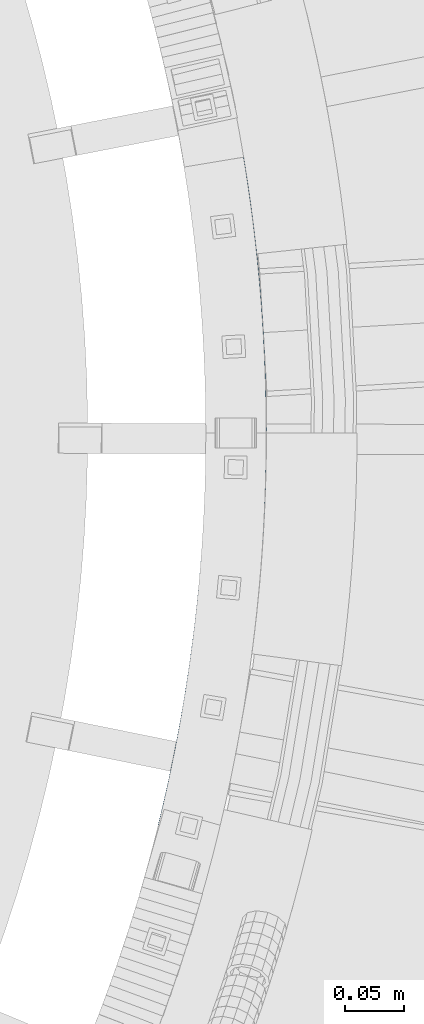
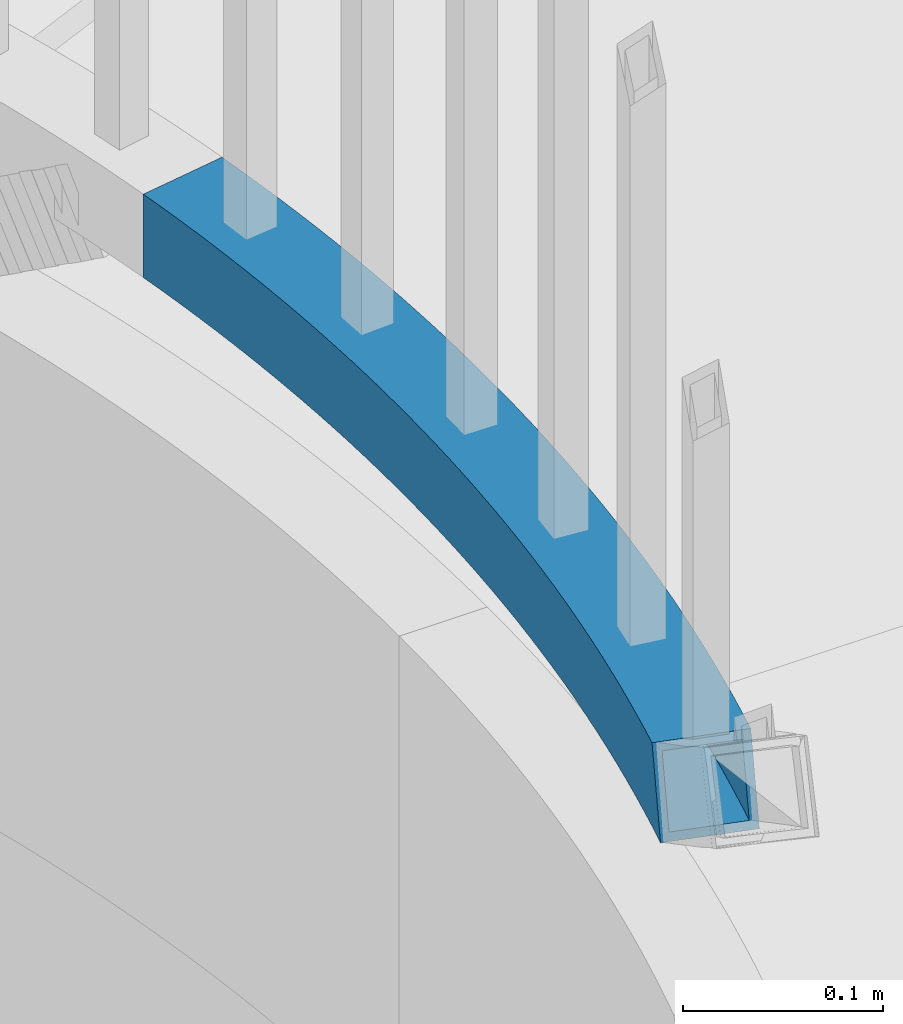
# One storey, part 500 of 975: 1 beam.
"""IFC2X3 building model written with IfcOpenShell, lengths in millimetres."""

from ifc_helpers import new_model, si_unit, frame, origin_with_axes, place, context, subcontext, project, spatial, faceted_brep, material, type_object, element, save


model = new_model("IFC2X3")

# Units and contexts
model_context = context("Model", 3, precision=1e-05, world=origin_with_axes())
body_context = subcontext(model_context, "Body", "Model", "MODEL_VIEW")
ifc_project = project(units=[si_unit("LENGTHUNIT", "METRE", prefix="MILLI"), si_unit("AREAUNIT", "SQUARE_METRE"), si_unit("VOLUMEUNIT", "CUBIC_METRE"), si_unit("MASSUNIT", "GRAM", prefix="KILO"), si_unit("TIMEUNIT", "SECOND"), si_unit("PLANEANGLEUNIT", "RADIAN"), si_unit("SOLIDANGLEUNIT", "STERADIAN"), si_unit("THERMODYNAMICTEMPERATUREUNIT", "DEGREE_CELSIUS"), si_unit("LUMINOUSINTENSITYUNIT", "LUMEN")], contexts=[model_context])

# Site, building, storey
site_placement = place(None, origin_with_axes())
site = spatial("IfcSite", under=ifc_project, at=site_placement, CompositionType="ELEMENT")
building_placement = place(site_placement, origin_with_axes())
building = spatial("IfcBuilding", under=site, at=building_placement, Name="Undefined", CompositionType="ELEMENT")
storey_placement = place(building_placement, origin_with_axes())
storey = spatial("IfcBuildingStorey", under=building, at=storey_placement, Name="Undefined", CompositionType="ELEMENT", Elevation=0.0)

# Beam
ifc_material = material()
beam_type = type_object("IfcBeamType", Name="HSS2X2X.188_TUBES", PredefinedType="NOTDEFINED")
beam_placement = place(storey_placement, frame((36112.7719804333, 3631.78783647588, 2298.70000076294), z_axis=(0.0, 0.0, 1.0), x_axis=(-0.152831050032776, -0.988252331211963, 0.0)))
element("IfcBeam", 1, at=beam_placement, inside=storey, type_object=beam_type, material=ifc_material, Name="HANDRAIL", ObjectType="HSS2X2X.188_TUBES", context=body_context, shape_type="Brep", body=[
    faceted_brep([(535.602146892454, 91.4649751076213, 25.4000000000001), (520.326512477557, 92.4485665877291, 25.4000000000001), (505.04121450457, 93.2683987988567, 25.4000000000001), (489.748008470178, 93.9243775843279, 25.4000000000001), (474.448650779292, 94.4164276058218, 25.4000000000001), (459.144898543333, 94.7444923520379, 25.4000000000001), (443.838509378433, 94.9085341451646, 25.4000000000001), (428.531241203566, 94.9085341452228, 25.4000000000001), (413.224852038664, 94.744492352198, 25.4000000000001), (397.921099802705, 94.4164276060765, 25.4000000000001), (382.621742111818, 93.9243775846844, 25.4000000000001), (367.328536077426, 93.268398799315, 25.4000000000001), (352.043238104439, 92.4485665882894, 25.4000000000001), (336.767603689541, 91.4649751082761, 25.4000000000001), (321.503387219564, 90.3177373234867, 25.4000000000001), (306.252341770007, 89.0069849926876, 25.4000000000001), (291.016218903691, 87.5328686540888, 25.4000000000001), (275.796768469605, 85.895557608048, 25.4000000000001), (260.59573840192, 84.0952398976151, 25.4000000000001), (245.414874519263, 82.1321222869374, 25.4000000000001), (230.255920324194, 80.006430237554, 25.4000000000001), (215.120616802971, 77.7184078824284, 25.4000000000001), (200.010702225611, 75.2683179979649, 25.4000000000001), (184.927911946239, 72.6564419738206, 25.4000000000001), (169.873978203786, 69.8830797805786, 25.4000000000001), (154.850629923059, 66.9485499352886, 25.4000000000001), (139.859592516148, 63.8531894648986, 25.4000000000001), (124.902587684295, 60.5973538675753, 25.4000000000001), (109.981333220136, 57.1814170717917, 25.4000000000001), (95.0975428104266, 53.6057713934788, 25.4000000000001), (80.2529258392278, 49.870827490915, 25.4000000000001), (65.4491871915761, 45.9770143175774, 25.4000000000001), (50.6880270576876, 41.9247790728405, 25.4000000000001), (35.9711407376926, 37.7145871507091, 25.4000000000001), (21.3002184469278, 33.3469220862535, 25.4000000000001), (6.67694512182607, 28.8222855001659, 25.4000000000001), (-7.89699977360578, 24.1411970410845, 25.4000000000001), (7.8969997736076, -24.1411970410918, 25.4000000000001), (21.9526148474361, -19.6265938928409, 25.4000000000001), (36.0558039600437, -15.26287832651, 25.4000000000001), (50.2049473784245, -11.0505515091718, 25.4000000000001), (64.3984200917712, -6.99009722112532, 25.4000000000001), (78.6345919981231, -3.0819818002783, 25.4000000000001), (92.9118280915682, 0.673345911382057, 25.4000000000001), (107.228488650027, 4.27545461931732, 25.4000000000001), (121.582929423572, 7.72393062600895, 25.4000000000001), (135.973501823266, 11.0183778784412, 25.4000000000001), (150.398553110501, 14.1584180136488, 25.4000000000001), (164.856426586812, 17.143690402052, 25.4000000000001), (179.345461784151, 19.9738521889958, 25.4000000000001), (193.863994655585, 22.6485783340613, 25.4000000000001), (208.410357766412, 25.1675616484135, 25.4000000000001), (222.982880485662, 27.5305128300824, 25.4000000000001), (237.579889177972, 29.737160497185, 25.4000000000001), (252.19970739579, 31.7872512190879, 25.4000000000001), (266.840656071921, 33.6805495455337, 25.4000000000001), (281.501053712373, 35.4168380336632, 25.4000000000001), (296.179216589451, 36.9959172729723, 25.4000000000001), (310.873458935159, 38.417605908282, 25.4000000000001), (325.582093134786, 39.6817406604678, 25.4000000000001), (340.303429920741, 40.7881763453115, 25.4000000000001), (355.035778566551, 41.7367858900907, 25.4000000000001), (369.777447081053, 42.5274603482394, 25.4000000000001), (384.526742402701, 43.1601089118121, 25.4000000000001), (399.281970594027, 43.6346589219465, 25.4000000000001), (414.041437036178, 43.9510558771872, 25.4000000000001), (428.803446623542, 44.1092634397428, 25.4000000000001), (443.566303958429, 44.1092634396919, 25.4000000000001), (458.328313545793, 43.9510558770344, 25.4000000000001), (473.087779987942, 43.6346589217064, 25.4000000000001), (487.843008179267, 43.1601089114702, 25.4000000000001), (502.592303500916, 42.5274603477956, 25.4000000000001), (517.333972015418, 41.7367858895523, 25.4000000000001), (532.066320661226, 40.7881763446712, 25.4000000000001), (544.641376281192, 39.8430522380586, 25.4000000000001), (550.866363362431, 90.3177373227227, 25.4000000000001), (546.787657447179, 39.6817406597329, -25.4000000000001), (559.66859210903, 38.5746876915873, -25.4000000000001), (546.787657447179, 39.6817406597329, 18.1526137053297), (532.066320661226, 40.7881763446712, -25.4000000000001), (517.333972015418, 41.7367858895523, -25.4000000000001), (502.592303500916, 42.5274603477956, -25.4000000000001), (487.843008179267, 43.1601089114702, -25.4000000000001), (473.087779987942, 43.6346589217064, -25.4000000000001), (458.328313545793, 43.9510558770344, -25.4000000000001), (443.566303958429, 44.1092634396919, -25.4000000000001), (428.803446623542, 44.1092634397428, -25.4000000000001), (414.041437036178, 43.9510558771872, -25.4000000000001), (399.281970594027, 43.6346589219465, -25.4000000000001), (384.526742402701, 43.1601089118121, -25.4000000000001), (369.777447081053, 42.5274603482394, -25.4000000000001), (355.035778566551, 41.7367858900907, -25.4000000000001), (340.303429920741, 40.7881763453115, -25.4000000000001), (325.582093134786, 39.6817406604678, -25.4000000000001), (310.873458935159, 38.417605908282, -25.4000000000001), (296.179216589451, 36.9959172729723, -25.4000000000001), (281.501053712373, 35.4168380336632, -25.4000000000001), (266.840656071921, 33.6805495455337, -25.4000000000001), (252.19970739579, 31.7872512190879, -25.4000000000001), (237.579889177972, 29.737160497185, -25.4000000000001), (222.982880485662, 27.5305128300824, -25.4000000000001), (208.410357766412, 25.1675616484135, -25.4000000000001), (193.863994655585, 22.6485783340613, -25.4000000000001), (179.345461784151, 19.9738521889958, -25.4000000000001), (164.856426586812, 17.143690402052, -25.4000000000001), (150.398553110501, 14.1584180136488, -25.4000000000001), (135.973501823266, 11.0183778784412, -25.4000000000001), (121.582929423572, 7.72393062600895, -25.4000000000001), (107.228488650027, 4.27545461931732, -25.4000000000001), (92.9118280915682, 0.673345911382057, -25.4000000000001), (78.6345919981231, -3.0819818002783, -25.4000000000001), (64.3984200917712, -6.99009722112532, -25.4000000000001), (50.2049473784245, -11.0505515091718, -25.4000000000001), (36.0558039600437, -15.26287832651, -25.4000000000001), (21.9526148474361, -19.6265938928409, -25.4000000000001), (7.8969997736076, -24.1411970410918, -25.4000000000001), (-7.89699977360578, 24.1411970410845, -25.4000000000001), (6.67694512182607, 28.8222855001659, -25.4000000000001), (21.3002184469278, 33.3469220862535, -25.4000000000001), (35.9711407376926, 37.7145871507091, -25.4000000000001), (50.6880270576876, 41.9247790728405, -25.4000000000001), (65.4491871915761, 45.9770143175774, -25.4000000000001), (80.2529258392278, 49.870827490915, -25.4000000000001), (95.0975428104266, 53.6057713934788, -25.4000000000001), (109.981333220136, 57.1814170717917, -25.4000000000001), (124.902587684295, 60.5973538675753, -25.4000000000001), (139.859592516148, 63.8531894648986, -25.4000000000001), (154.850629923059, 66.9485499352886, -25.4000000000001), (169.873978203786, 69.8830797805786, -25.4000000000001), (184.927911946239, 72.6564419738206, -25.4000000000001), (200.010702225611, 75.2683179979649, -25.4000000000001), (215.120616802971, 77.7184078824284, -25.4000000000001), (230.255920324194, 80.006430237554, -25.4000000000001), (245.414874519263, 82.1321222869374, -25.4000000000001), (260.59573840192, 84.0952398976151, -25.4000000000001), (275.796768469605, 85.895557608048, -25.4000000000001), (291.016218903691, 87.5328686540888, -25.4000000000001), (306.252341770007, 89.0069849926876, -25.4000000000001), (321.503387219564, 90.3177373234867, -25.4000000000001), (336.767603689541, 91.4649751082761, -25.4000000000001), (352.043238104439, 92.4485665882894, -25.4000000000001), (367.328536077426, 93.268398799315, -25.4000000000001), (382.621742111818, 93.9243775846844, -25.4000000000001), (397.921099802705, 94.4164276060765, -25.4000000000001), (413.224852038664, 94.744492352198, -25.4000000000001), (428.531241203566, 94.9085341452228, -25.4000000000001), (443.838509378433, 94.9085341451646, -25.4000000000001), (459.144898543333, 94.7444923520379, -25.4000000000001), (474.448650779292, 94.4164276058218, -25.4000000000001), (489.748008470178, 93.9243775843279, -25.4000000000001), (505.04121450457, 93.2683987988567, -25.4000000000001), (520.326512477557, 92.4485665877291, -25.4000000000001), (535.602146892454, 91.4649751076213, -25.4000000000001), (550.866363362431, 90.3177373227227, -25.4000000000001), (566.11740881199, 89.0069849918145, -25.4000000000001), (517.614522683742, 46.4910153300079, -20.6374999999998), (517.614522683742, 46.4910153300079, 20.6374999999998), (532.397804370406, 45.5391262286939, 20.6374999999998), (532.397804370406, 45.5391262286939, -20.6374999999998), (502.821888907509, 47.2844233275828, -20.6374999999998), (502.821888907509, 47.2844233275828, 20.6374999999998), (488.021601956541, 47.9192590995517, -20.6374999999998), (488.021601956541, 47.9192590995517, 20.6374999999998), (473.215361624631, 48.3954497358427, -20.6374999999998), (473.215361624631, 48.3954497358427, 20.6374999999998), (458.404868389312, 48.7129405465676, -20.6374999999998), (458.404868389312, 48.7129405465676, 20.6374999999998), (443.591823216555, 48.8716950683302, -20.6374999999998), (443.591823216555, 48.8716950683302, 20.6374999999998), (428.777927365418, 48.8716950683811, -20.6374999999998), (428.777927365418, 48.8716950683811, 20.6374999999998), (413.964882192662, 48.7129405467131, -20.6374999999998), (413.964882192662, 48.7129405467131, 20.6374999999998), (399.15438895734, 48.3954497360901, -20.6374999999998), (399.15438895734, 48.3954497360901, 20.6374999999998), (384.348148625431, 47.9192590998937, -20.6374999999998), (384.348148625431, 47.9192590998937, 20.6374999999998), (369.547861674464, 47.2844233280266, -20.6374999999998), (369.547861674464, 47.2844233280266, 20.6374999999998), (354.755227898229, 46.4910153305464, -20.6374999999998), (354.755227898229, 46.4910153305464, 20.6374999999998), (339.971946211566, 45.5391262293342, -20.6374999999998), (339.971946211566, 45.5391262293342, 20.6374999999998), (325.199714455235, 44.4288653476251, -20.6374999999998), (325.199714455235, 44.4288653476251, 20.6374999999998), (310.440229200925, 43.1603601974421, -20.6374999999998), (310.440229200925, 43.1603601974421, 20.6374999999998), (295.695185556411, 41.733756464957, -20.6374999999998), (295.695185556411, 41.733756464957, 20.6374999999998), (280.966276970861, 40.1492179937632, -20.6374999999998), (280.966276970861, 40.1492179937632, 20.6374999999998), (266.255195040359, 38.4069267660379, -20.6374999999998), (266.255195040359, 38.4069267660379, 20.6374999999998), (251.563629313614, 36.5070828817043, -20.6374999999998), (251.563629313614, 36.5070828817043, 20.6374999999998), (236.89326709793, 34.4499045353441, -20.6374999999998), (236.89326709793, 34.4499045353441, 20.6374999999998), (222.245793265411, 32.2356279912419, -20.6374999999998), (222.245793265411, 32.2356279912419, 20.6374999999998), (207.622890059461, 29.8645075561872, -20.6374999999998), (207.622890059461, 29.8645075561872, 20.6374999999998), (193.026236901582, 27.3368155502903, -20.6374999999998), (193.026236901582, 27.3368155502903, 20.6374999999998), (178.457510198492, 24.6528422757037, -20.6374999999998), (178.457510198492, 24.6528422757037, 20.6374999999998), (163.918383149585, 21.8128959832902, -20.6374999999998), (163.918383149585, 21.8128959832902, 20.6374999999998), (149.41052555478, 18.8173028371966, -20.6374999999998), (149.41052555478, 18.8173028371966, 20.6374999999998), (134.935603622738, 15.6664068774335, -20.6374999999998), (134.935603622738, 15.6664068774335, 20.6374999999998), (120.495279779501, 12.3605699803011, -20.6374999999998), (120.495279779501, 12.3605699803011, 20.6374999999998), (106.091212477566, 8.90017181688745, -20.6374999999998), (106.091212477566, 8.90017181688745, 20.6374999999998), (91.7250560054108, 5.28560980946349, -20.6374999999998), (91.7250560054108, 5.28560980946349, 20.6374999999998), (77.3984602975088, 1.51729908577545, -20.6374999999998), (77.3984602975088, 1.51729908577545, 20.6374999999998), (63.1130707448265, -2.40432756856899, -20.6374999999998), (63.1130707448265, -2.40432756856899, 20.6374999999998), (48.8705280058548, -6.47881975980999, -20.6374999999998), (48.8705280058548, -6.47881975980999, 20.6374999999998), (34.6724678181909, -10.7057095378113, -20.6374999999998), (34.6724678181909, -10.7057095378113, 20.6374999999998), (20.5205208106599, -15.0845114497424, -20.6374999999998), (20.5205208106599, -15.0845114497424, 20.6374999999998), (6.41631231605606, -19.6147225958921, -20.6374999999998), (6.41631231605606, -19.6147225958921, 20.6374999999998), (-6.41631231605606, 19.6147225958848, 20.6374999999998), (-6.41631231605606, 19.6147225958848, -20.6374999999998), (8.10903915860217, 24.2802030570747, -20.6374999999998), (8.10903915860217, 24.2802030570747, 20.6374999999998), (22.6835545887825, 28.7897532975621, -20.6374999999998), (22.6835545887825, 28.7897532975621, 20.6374999999998), (37.3055601102606, 33.1428554013401, -20.6374999999998), (37.3055601102606, 33.1428554013401, 20.6374999999998), (51.9733764046323, 37.3390094202841, -20.6374999999998), (51.9733764046323, 37.3390094202841, 20.6374999999998), (66.6853188921905, 41.3777334315164, -20.6374999999998), (66.6853188921905, 41.3777334315164, 20.6374999999998), (81.4396979253852, 45.2585635928335, -20.6374999999998), (81.4396979253852, 45.2585635928335, 20.6374999999998), (96.2348189828899, 48.9810541959014, -20.6374999999998), (96.2348189828899, 48.9810541959014, 20.6374999999998), (111.068982864208, 52.5447777174923, -20.6374999999998), (111.068982864208, 52.5447777174923, 20.6374999999998), (125.940485884823, 55.9493248685831, -20.6374999999998), (125.940485884823, 55.9493248685831, 20.6374999999998), (140.847620071869, 59.1943046413508, -20.6374999999998), (140.847620071869, 59.1943046413508, 20.6374999999998), (155.788673360285, 62.2793443540504, -20.6374999999998), (155.788673360285, 62.2793443540504, 20.6374999999998), (170.761929789447, 65.2040896938706, -20.6374999999998), (170.761929789447, 65.2040896938706, 20.6374999999998), (185.76566970024, 67.9682047575916, -20.6374999999998), (185.76566970024, 67.9682047575916, 20.6374999999998), (200.798169932561, 70.5713720901986, -20.6374999999998), (200.798169932561, 70.5713720901986, 20.6374999999998), (215.857704023223, 73.013292721269, -20.6374999999998), (215.857704023223, 73.013292721269, 20.6374999999998), (230.942542404235, 75.2936861993949, -20.6374999999998), (230.942542404235, 75.2936861993949, 20.6374999999998), (246.050952601438, 77.4122906243356, -20.6374999999998), (246.050952601438, 77.4122906243356, 20.6374999999998), (261.181199433484, 79.3688626771109, -20.6374999999998), (261.181199433484, 79.3688626771109, 20.6374999999998), (276.331545211115, 81.163177647948, -20.6374999999998), (276.331545211115, 81.163177647948, 20.6374999999998), (291.500249936731, 82.7950294621114, -20.6374999999998), (291.500249936731, 82.7950294621114, 20.6374999999998), (306.685571504238, 84.2642307035276, -20.6374999999998), (306.685571504238, 84.2642307035276, 20.6374999999998), (321.885765899116, 85.5706126363293, -20.6374999999998), (321.885765899116, 85.5706126363293, 20.6374999999998), (337.099087398716, 86.7140252242607, -20.6374999999998), (337.099087398716, 86.7140252242607, 20.6374999999998), (352.323788772763, 87.6943371478337, -20.6374999999998), (352.323788772763, 87.6943371478337, 20.6374999999998), (367.558121484017, 88.5114358195206, -20.6374999999998), (367.558121484017, 88.5114358195206, 20.6374999999998), (382.800335889087, 89.1652273966029, -20.6374999999998), (382.800335889087, 89.1652273966029, 20.6374999999998), (398.04868143939, 89.6556367919475, -20.6374999999998), (398.04868143939, 89.6556367919475, 20.6374999999998), (413.301406882181, 89.9826076826648, -20.6374999999998), (413.301406882181, 89.9826076826648, 20.6374999999998), (428.556760461688, 90.1461025165845, -20.6374999999998), (428.556760461688, 90.1461025165845, 20.6374999999998), (443.812990120306, 90.1461025165336, -20.6374999999998), (443.812990120306, 90.1461025165336, 20.6374999999998), (459.068343699813, 89.9826076825047, -20.6374999999998), (459.068343699813, 89.9826076825047, 20.6374999999998), (474.321069142603, 89.6556367916855, -20.6374999999998), (474.321069142603, 89.6556367916855, 20.6374999999998), (489.569414692905, 89.1652273962463, -20.6374999999998), (489.569414692905, 89.1652273962463, 20.6374999999998), (504.811629097978, 88.5114358190694, -20.6374999999998), (504.811629097978, 88.5114358190694, 20.6374999999998), (520.04596180923, 87.6943371472735, -20.6374999999998), (520.04596180923, 87.6943371472735, 20.6374999999998), (535.270663183279, 86.7140252235913, -20.6374999999998), (535.270663183279, 86.7140252235913, 20.6374999999998), (550.483984682878, 85.5706126355653, -20.6374999999998), (550.483984682878, 85.5706126355653, 20.6374999999998), (563.898889685914, 84.4176675433991, -20.6374999999998), (551.691572307331, 85.4668264198117, 20.6374999999998), (546.635361979379, 44.469050729851, 20.6374999999998), (547.170036126736, 44.428865346883, -20.6374999999998), (547.170036126736, 44.428865346883, 18.8320561704218), (558.843383164025, 43.4255985945128, -20.6374999999998)], [[[0, 1, 2, 3, 4, 5, 6, 7, 8, 9, 10, 11, 12, 13, 14, 15, 16, 17, 18, 19, 20, 21, 22, 23, 24, 25, 26, 27, 28, 29, 30, 31, 32, 33, 34, 35, 36, 37, 38, 39, 40, 41, 42, 43, 44, 45, 46, 47, 48, 49, 50, 51, 52, 53, 54, 55, 56, 57, 58, 59, 60, 61, 62, 63, 64, 65, 66, 67, 68, 69, 70, 71, 72, 73, 74, 75]], [[76, 77, 78]], [[73, 79, 76, 78, 74]], [[72, 80, 79, 73]], [[71, 81, 80, 72]], [[70, 82, 81, 71]], [[69, 83, 82, 70]], [[68, 84, 83, 69]], [[67, 85, 84, 68]], [[66, 86, 85, 67]], [[65, 87, 86, 66]], [[64, 88, 87, 65]], [[63, 89, 88, 64]], [[62, 90, 89, 63]], [[61, 91, 90, 62]], [[60, 92, 91, 61]], [[59, 93, 92, 60]], [[58, 94, 93, 59]], [[57, 95, 94, 58]], [[56, 96, 95, 57]], [[55, 97, 96, 56]], [[54, 98, 97, 55]], [[53, 99, 98, 54]], [[52, 100, 99, 53]], [[51, 101, 100, 52]], [[50, 102, 101, 51]], [[49, 103, 102, 50]], [[48, 104, 103, 49]], [[47, 105, 104, 48]], [[46, 106, 105, 47]], [[45, 107, 106, 46]], [[44, 108, 107, 45]], [[43, 109, 108, 44]], [[42, 110, 109, 43]], [[41, 111, 110, 42]], [[40, 112, 111, 41]], [[39, 113, 112, 40]], [[38, 114, 113, 39]], [[37, 115, 114, 38]], [[76, 79, 80, 81, 82, 83, 84, 85, 86, 87, 88, 89, 90, 91, 92, 93, 94, 95, 96, 97, 98, 99, 100, 101, 102, 103, 104, 105, 106, 107, 108, 109, 110, 111, 112, 113, 114, 115, 116, 117, 118, 119, 120, 121, 122, 123, 124, 125, 126, 127, 128, 129, 130, 131, 132, 133, 134, 135, 136, 137, 138, 139, 140, 141, 142, 143, 144, 145, 146, 147, 148, 149, 150, 151, 152, 153, 154, 77]], [[153, 75, 154]], [[152, 0, 75, 153]], [[151, 1, 0, 152]], [[150, 2, 1, 151]], [[149, 3, 2, 150]], [[148, 4, 3, 149]], [[147, 5, 4, 148]], [[146, 6, 5, 147]], [[145, 7, 6, 146]], [[144, 8, 7, 145]], [[143, 9, 8, 144]], [[142, 10, 9, 143]], [[141, 11, 10, 142]], [[140, 12, 11, 141]], [[139, 13, 12, 140]], [[138, 14, 13, 139]], [[137, 15, 14, 138]], [[136, 16, 15, 137]], [[135, 17, 16, 136]], [[134, 18, 17, 135]], [[133, 19, 18, 134]], [[132, 20, 19, 133]], [[131, 21, 20, 132]], [[130, 22, 21, 131]], [[129, 23, 22, 130]], [[128, 24, 23, 129]], [[127, 25, 24, 128]], [[126, 26, 25, 127]], [[125, 27, 26, 126]], [[124, 28, 27, 125]], [[123, 29, 28, 124]], [[122, 30, 29, 123]], [[121, 31, 30, 122]], [[120, 32, 31, 121]], [[119, 33, 32, 120]], [[118, 34, 33, 119]], [[117, 35, 34, 118]], [[116, 36, 35, 117]], [[155, 156, 157, 158]], [[159, 160, 156, 155]], [[161, 162, 160, 159]], [[163, 164, 162, 161]], [[165, 166, 164, 163]], [[167, 168, 166, 165]], [[169, 170, 168, 167]], [[171, 172, 170, 169]], [[173, 174, 172, 171]], [[175, 176, 174, 173]], [[177, 178, 176, 175]], [[179, 180, 178, 177]], [[181, 182, 180, 179]], [[183, 184, 182, 181]], [[185, 186, 184, 183]], [[187, 188, 186, 185]], [[189, 190, 188, 187]], [[191, 192, 190, 189]], [[193, 194, 192, 191]], [[195, 196, 194, 193]], [[197, 198, 196, 195]], [[199, 200, 198, 197]], [[201, 202, 200, 199]], [[203, 204, 202, 201]], [[205, 206, 204, 203]], [[207, 208, 206, 205]], [[209, 210, 208, 207]], [[211, 212, 210, 209]], [[213, 214, 212, 211]], [[215, 216, 214, 213]], [[217, 218, 216, 215]], [[219, 220, 218, 217]], [[221, 222, 220, 219]], [[223, 224, 222, 221]], [[225, 226, 224, 223]], [[227, 228, 226, 225]], [[115, 37, 36, 116], [229, 228, 227, 230]], [[229, 230, 231, 232]], [[232, 231, 233, 234]], [[234, 233, 235, 236]], [[236, 235, 237, 238]], [[238, 237, 239, 240]], [[240, 239, 241, 242]], [[242, 241, 243, 244]], [[244, 243, 245, 246]], [[246, 245, 247, 248]], [[248, 247, 249, 250]], [[250, 249, 251, 252]], [[252, 251, 253, 254]], [[254, 253, 255, 256]], [[256, 255, 257, 258]], [[258, 257, 259, 260]], [[260, 259, 261, 262]], [[262, 261, 263, 264]], [[264, 263, 265, 266]], [[266, 265, 267, 268]], [[268, 267, 269, 270]], [[270, 269, 271, 272]], [[272, 271, 273, 274]], [[274, 273, 275, 276]], [[276, 275, 277, 278]], [[278, 277, 279, 280]], [[280, 279, 281, 282]], [[282, 281, 283, 284]], [[284, 283, 285, 286]], [[286, 285, 287, 288]], [[288, 287, 289, 290]], [[290, 289, 291, 292]], [[292, 291, 293, 294]], [[294, 293, 295, 296]], [[296, 295, 297, 298]], [[298, 297, 299, 300]], [[300, 299, 301, 302]], [[302, 301, 303, 304]], [[304, 303, 305, 306]], [[157, 156, 160, 162, 164, 166, 168, 170, 172, 174, 176, 178, 180, 182, 184, 186, 188, 190, 192, 194, 196, 198, 200, 202, 204, 206, 208, 210, 212, 214, 216, 218, 220, 222, 224, 226, 228, 229, 232, 234, 236, 238, 240, 242, 244, 246, 248, 250, 252, 254, 256, 258, 260, 262, 264, 266, 268, 270, 272, 274, 276, 278, 280, 282, 284, 286, 288, 290, 292, 294, 296, 298, 300, 302, 304, 306, 307]], [[308, 158, 157, 307, 309]], [[308, 309, 310]], [[303, 301, 299, 297, 295, 293, 291, 289, 287, 285, 283, 281, 279, 277, 275, 273, 271, 269, 267, 265, 263, 261, 259, 257, 255, 253, 251, 249, 247, 245, 243, 241, 239, 237, 235, 233, 231, 230, 227, 225, 223, 221, 219, 217, 215, 213, 211, 209, 207, 205, 203, 201, 199, 197, 195, 193, 191, 189, 187, 185, 183, 181, 179, 177, 175, 173, 171, 169, 167, 165, 163, 161, 159, 155, 158, 308, 310, 305]], [[74, 78, 77, 154, 75], [309, 307, 306, 305, 310]]]),
])

save(model, "model.ifc")
